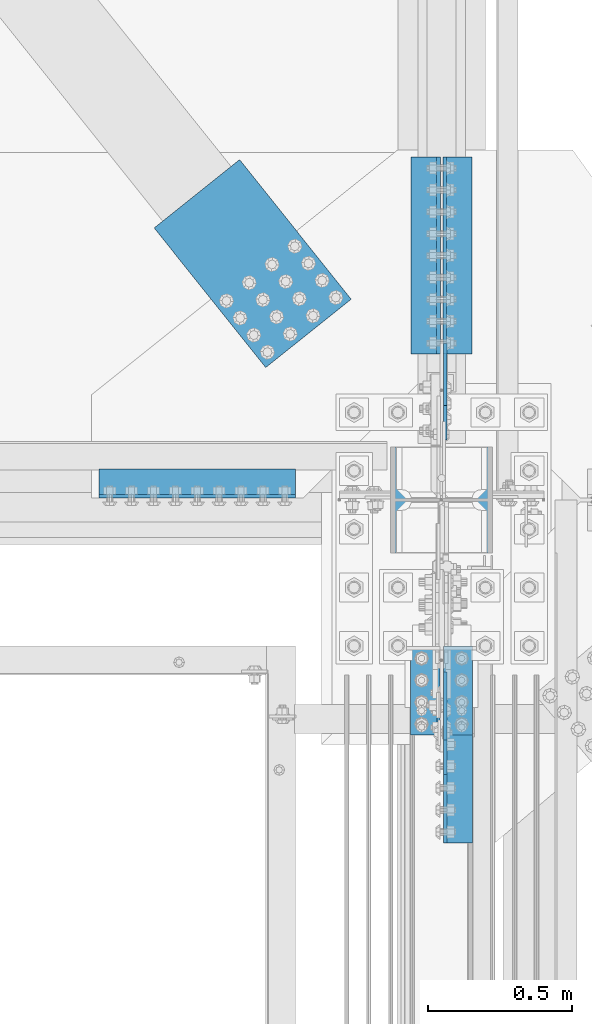
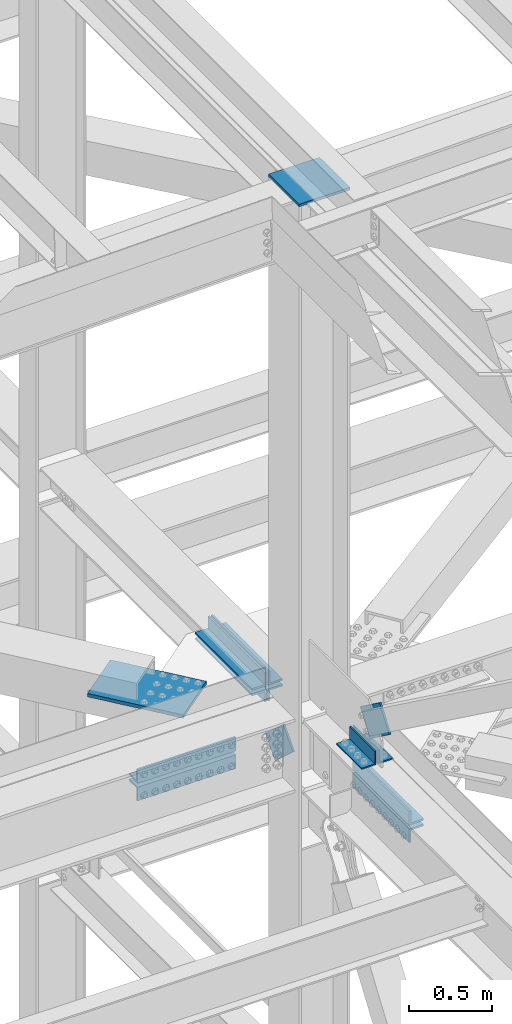
# One storey, part 2171 of 3843: 12 beams, 2 members, 9 elements without a shape of their own.
"""IFC2X3 building model written with IfcOpenShell, lengths in millimetres."""

import ifcopenshell
import ifcopenshell.guid

model = None  # the IFC model being written
_history = None  # IfcOwnerHistory: only IFC2X3 demands one
_inside = {}  # id of a spatial element -> (the spatial element, [elements in it])
_under = {}  # id of a project, library or spatial element -> (it, [spatial elements below it])
_declared = {}  # id of a project -> (the project, [libraries it declares])
_typed = {}  # id of a type object -> (the type object, [elements of that type])
_made_of = {}  # id of a material, layer set ... -> (it, [elements and type objects made of it])


def new_model(schema):
    """Start an empty IFC model of exactly this schema.

    Asked for "IFC4X3", IfcOpenShell would pick the latest addendum, in which some entities
    have other attributes; the version numbers below select the first issue.
    IFC2X3 requires an IfcOwnerHistory on every rooted entity: one is made here for all.
    """
    global model, _history
    if schema == "IFC4X3":
        model = ifcopenshell.file(schema_version=(4, 3, 0, 0))
    else:
        model = ifcopenshell.file(schema=schema)
    _inside.clear()
    _under.clear()
    _declared.clear()
    _typed.clear()
    _made_of.clear()
    _history = None
    if model.schema == "IFC2X3":
        org = make("IfcOrganization", Name="unknown")
        user = make(
            "IfcPersonAndOrganization",
            ThePerson=make("IfcPerson", FamilyName="unknown"),
            TheOrganization=org,
        )
        app = make(
            "IfcApplication",
            ApplicationDeveloper=org,
            Version="unknown",
            ApplicationFullName="unknown",
            ApplicationIdentifier="unknown",
        )
        _history = make(
            "IfcOwnerHistory",
            OwningUser=user,
            OwningApplication=app,
            ChangeAction="ADDED",
            CreationDate=0,
        )
    return model


def make(cls, **values):
    """One entity of the class cls with the attributes given. An attribute that is None is left unset."""
    return model.create_entity(
        cls, **{name: value for name, value in values.items() if value is not None}
    )


def rooted(cls, **values):
    """An entity with a GlobalId (a new one), such as an element, a storey or a relation."""
    return make(cls, GlobalId=ifcopenshell.guid.new(), OwnerHistory=_history, **values)


def si_unit(unit_type, name, prefix=None):
    """IfcSIUnit, for example si_unit("LENGTHUNIT", "METRE", prefix="MILLI")."""
    return make("IfcSIUnit", UnitType=unit_type, Prefix=prefix, Name=name)


def assignment(units):
    """IfcUnitAssignment: the units of a project."""
    return None if units is None else make("IfcUnitAssignment", Units=units)


def point(xyz):
    """IfcCartesianPoint."""
    return None if xyz is None else make("IfcCartesianPoint", Coordinates=xyz)


def direction(xyz):
    """IfcDirection."""
    return None if xyz is None else make("IfcDirection", DirectionRatios=xyz)


def frame(location, z_axis=None, x_axis=None):
    """IfcAxis2Placement3D, a coordinate frame: its origin and axes. An axis left out is left unset."""
    return make(
        "IfcAxis2Placement3D",
        Location=point(location),
        Axis=direction(z_axis),
        RefDirection=direction(x_axis),
    )


def origin_with_axes():
    """The frame at (0, 0, 0) with the z axis (0, 0, 1) and the x axis (1, 0, 0) written out."""
    return frame((0.0, 0.0, 0.0), z_axis=(0.0, 0.0, 1.0), x_axis=(1.0, 0.0, 0.0))


def place(relative_to, where):
    """IfcLocalPlacement: puts the frame where relative to a parent placement (None: the world)."""
    return make(
        "IfcLocalPlacement", PlacementRelTo=relative_to, RelativePlacement=where
    )


def context(
    kind, dimensions, precision=None, world=None, true_north=None, identifier=None
):
    """IfcGeometricRepresentationContext, for example the 3D "Model" context."""
    return make(
        "IfcGeometricRepresentationContext",
        ContextIdentifier=identifier,
        ContextType=kind,
        CoordinateSpaceDimension=dimensions,
        Precision=precision,
        WorldCoordinateSystem=world,
        TrueNorth=true_north,
    )


def subcontext(parent, identifier, kind, view, scale=None):
    """IfcGeometricRepresentationSubContext, for example "Body" below "Model"."""
    return make(
        "IfcGeometricRepresentationSubContext",
        ContextIdentifier=identifier,
        ContextType=kind,
        ParentContext=parent,
        TargetScale=scale,
        TargetView=view,
    )


def project(units=None, contexts=None):
    """IfcProject with its units and contexts."""
    return rooted(
        "IfcProject",
        Name="project",
        RepresentationContexts=contexts,
        UnitsInContext=assignment(units),
    )


def spatial(cls, under=None, at=None, **own):
    """A site, building, storey or space (cls), placed at a placement, below another one or the project."""
    s = rooted(cls, ObjectPlacement=at, **own)
    if under is not None:
        _under.setdefault(under.id(), (under, []))[1].append(s)
    return s


def faces_of(points, faces, orient=None, outer=None):
    """IfcFace entities. A face is a list of loops; a loop is a list of indices into points, from 0.

    orient and outer hold one flag for each loop. By default every Orientation is true, the
    first loop of a face is its IfcFaceOuterBound and the others are IfcFaceBound.
    """
    made = []
    for i, loops in enumerate(faces):
        bounds = []
        for j, loop in enumerate(loops):
            is_outer = j == 0 if outer is None else outer[i][j]
            bounds.append(
                make(
                    "IfcFaceOuterBound" if is_outer else "IfcFaceBound",
                    Bound=make("IfcPolyLoop", Polygon=[points[k] for k in loop]),
                    Orientation=True if orient is None else orient[i][j],
                )
            )
        made.append(make("IfcFace", Bounds=bounds))
    return made


def faceted_brep(points, faces, orient=None, outer=None, voids=None):
    """IfcFacetedBrep: a solid bounded by flat faces; with voids (closed shells), ...WithVoids."""
    shared = [point(p) for p in points]
    hull = make("IfcClosedShell", CfsFaces=faces_of(shared, faces, orient, outer))
    if voids is None:
        return make("IfcFacetedBrep", Outer=hull)
    return make(
        "IfcFacetedBrepWithVoids",
        Outer=hull,
        Voids=[
            make(cls, CfsFaces=faces_of(shared, fs, o, b)) for cls, fs, o, b in voids
        ],
    )


def shape(context_of_items, identifier, shape_type, items):
    """IfcShapeRepresentation: the items that make up one representation, for example the "Body"."""
    return make(
        "IfcShapeRepresentation",
        ContextOfItems=context_of_items,
        RepresentationIdentifier=identifier,
        RepresentationType=shape_type,
        Items=items,
    )


def material(Name=None, Category=None):
    """IfcMaterial."""
    return make("IfcMaterial", Name=Name, Category=Category)


def made_of(thing, what):
    """Note that an element or type object is made of a material, layer set ...; save() writes the relation."""
    if what is not None:
        _made_of.setdefault(what.id(), (what, []))[1].append(thing)
    return thing


def type_object(cls, material=None, **own):
    """A type object (cls), such as IfcWallType, which elements share."""
    return made_of(rooted(cls, **own), material)


def element(
    cls,
    number,
    at=None,
    inside=None,
    cuts=None,
    type_object=None,
    material=None,
    context=None,
    identifier="Body",
    shape_type=None,
    held_by="IfcProductDefinitionShape",
    body=None,
    shapes=None,
    **own,
):
    """One element of the class cls, such as IfcWall. Its Tag is "e" and its number.

    at: its placement. inside: the storey or other place that contains it. cuts: it is an
    opening in that element (IfcRelVoidsElement). A single representation is given by context,
    identifier, shape_type and body (its items); several are given by shapes. held_by: the class
    of the entity that holds the representations. save() writes the other relations.
    """
    e = rooted(cls, Tag="e%d" % number, ObjectPlacement=at, **own)
    if body is not None:
        shapes = [shape(context, identifier, shape_type, body)]
    if shapes is not None:
        e.Representation = make(held_by, Representations=shapes)
    if inside is not None:
        _inside.setdefault(inside.id(), (inside, []))[1].append(e)
    if cuts is not None:
        rooted(
            "IfcRelVoidsElement", RelatingBuildingElement=cuts, RelatedOpeningElement=e
        )
    if type_object is not None:
        _typed.setdefault(type_object.id(), (type_object, []))[1].append(e)
    return made_of(e, material)


def aggregate(whole, parts):
    """IfcRelAggregates: a whole, such as a stair, and the parts it consists of."""
    return rooted("IfcRelAggregates", RelatingObject=whole, RelatedObjects=parts)


def save(model, path):
    """Write the relations noted so far, then the file.

    IfcRelAggregates (storeys below a building ...), IfcRelContainedInSpatialStructure (elements
    in a storey), IfcRelDefinesByType, IfcRelAssociatesMaterial and IfcRelDeclares: one each for
    every whole, place, type object, material and project.
    """
    for whole, parts in _under.values():
        aggregate(whole, parts)
    for where, things in _inside.values():
        rooted(
            "IfcRelContainedInSpatialStructure",
            RelatedElements=things,
            RelatingStructure=where,
        )
    for kind, things in _typed.values():
        rooted("IfcRelDefinesByType", RelatedObjects=things, RelatingType=kind)
    for what, things in _made_of.values():
        rooted("IfcRelAssociatesMaterial", RelatedObjects=things, RelatingMaterial=what)
    for by, libraries in _declared.values():
        rooted("IfcRelDeclares", RelatingContext=by, RelatedDefinitions=libraries)
    model.write(path)


model = new_model("IFC2X3")

# Units and contexts
model_context = context("Model", 3, precision=1e-05, world=origin_with_axes())
body_context = subcontext(model_context, "Body", "Model", "MODEL_VIEW")
ifc_project = project(units=[si_unit("LENGTHUNIT", "METRE", prefix="MILLI"), si_unit("AREAUNIT", "SQUARE_METRE"), si_unit("VOLUMEUNIT", "CUBIC_METRE"), si_unit("MASSUNIT", "GRAM", prefix="KILO"), si_unit("TIMEUNIT", "SECOND"), si_unit("PLANEANGLEUNIT", "RADIAN"), si_unit("SOLIDANGLEUNIT", "STERADIAN"), si_unit("THERMODYNAMICTEMPERATUREUNIT", "DEGREE_CELSIUS"), si_unit("LUMINOUSINTENSITYUNIT", "LUMEN")], contexts=[model_context])

# Site, building, storey
site_placement = place(None, origin_with_axes())
site = spatial("IfcSite", under=ifc_project, at=site_placement, CompositionType="ELEMENT")
building_placement = place(site_placement, origin_with_axes())
building = spatial("IfcBuilding", under=site, at=building_placement, Name="Undefined", CompositionType="ELEMENT")
storey_placement = place(building_placement, origin_with_axes())
storey = spatial("IfcBuildingStorey", under=building, at=storey_placement, Name="Undefined", CompositionType="ELEMENT", Elevation=0.0)

# Assembly, beam
assembly_1_placement = place(storey_placement, origin_with_axes())
assembly_1 = element("IfcElementAssembly", 1, at=assembly_1_placement, inside=storey, Name="ANGLE", AssemblyPlace="NOTDEFINED", PredefinedType="RIGID_FRAME")
ifc_material = material(Name="STEEL/A572-50")
beam_type_1 = type_object("IfcBeamType", Name="L4X4X3/8", PredefinedType="NOTDEFINED")
beam_1_placement = place(assembly_1_placement, frame((77069.9499999709, 24797.5437500067, 42519.5999999896), z_axis=(0.0, 0.0, 1.0), x_axis=(0.0, 1.0, 0.0)))
beam_1 = element("IfcBeam", 2, at=beam_1_placement, type_object=beam_type_1, material=ifc_material, Name="ANGLE", ObjectType="L4X4X3/8", context=body_context, shape_type="Brep", body=[
    faceted_brep([(0.0, 50.8000000000029, -50.8000000000029), (0.0, 50.8000000000029, 50.8000000000029), (304.800000000003, 50.8000000000029, 50.8000000000029), (304.800000000003, 50.8000000000029, -50.8000000000029), (0.0, 41.2750000000015, 50.8000000000029), (304.800000000003, 41.2749999999942, 50.8000000000029), (0.0, 41.2749999999942, -41.2750000000015), (304.800000000003, 41.2749999999942, -41.2750000000015), (0.0, -50.8000000000029, -41.2750000000015), (304.800000000003, -50.8000000000029, -41.2750000000015), (0.0, -50.8000000000029, -50.8000000000029), (304.800000000003, -50.8000000000029, -50.8000000000029)], [[[0, 1, 2, 3]], [[1, 4, 5, 2]], [[4, 6, 7, 5]], [[6, 8, 9, 7]], [[8, 10, 11, 9]], [[10, 0, 3, 11]], [[5, 7, 9, 11, 3, 2]], [[10, 8, 6, 4, 1, 0]]]),
])
aggregate(assembly_1, [beam_1])

assembly_2_placement = place(storey_placement, origin_with_axes())
assembly_2 = element("IfcElementAssembly", 3, at=assembly_2_placement, inside=storey, Name="ANGLE", AssemblyPlace="NOTDEFINED", PredefinedType="RIGID_FRAME")
beam_2_placement = place(assembly_2_placement, frame((76955.6499999709, 25102.3437500067, 42519.5999999896), z_axis=(0.0, 0.0, 1.0), x_axis=(0.0, -1.0, 0.0)))
beam_2 = element("IfcBeam", 4, at=beam_2_placement, type_object=beam_type_1, material=ifc_material, Name="ANGLE", ObjectType="L4X4X3/8", context=body_context, shape_type="Brep", body=[
    faceted_brep([(0.0, 50.8000000000029, -50.8000000000029), (0.0, 50.8000000000029, 50.8000000000029), (304.800000000003, 50.8000000000029, 50.8000000000029), (304.800000000003, 50.8000000000029, -50.8000000000029), (0.0, 41.2750000000015, 50.8000000000029), (304.800000000003, 41.2749999999942, 50.8000000000029), (0.0, 41.2749999999942, -41.2750000000015), (304.800000000003, 41.2749999999942, -41.2750000000015), (0.0, -50.8000000000029, -41.2750000000015), (304.800000000003, -50.8000000000029, -41.2750000000015), (0.0, -50.8000000000029, -50.8000000000029), (304.800000000003, -50.8000000000029, -50.8000000000029)], [[[0, 1, 2, 3]], [[1, 4, 5, 2]], [[4, 6, 7, 5]], [[6, 8, 9, 7]], [[8, 10, 11, 9]], [[10, 0, 3, 11]], [[5, 7, 9, 11, 3, 2]], [[10, 8, 6, 4, 1, 0]]]),
])
aggregate(assembly_2, [beam_2])

# Assembly, beams
assembly_3_placement = place(storey_placement, origin_with_axes())
assembly_3 = element("IfcElementAssembly", 5, at=assembly_3_placement, inside=storey, Name="PLATE", AssemblyPlace="NOTDEFINED", PredefinedType="RIGID_FRAME")
beam_type_2 = type_object("IfcBeamType", Name="L4X4X1/2", PredefinedType="NOTDEFINED")
beam_3_placement = place(assembly_3_placement, frame((77069.9499999965, 25107.9, 42297.35), z_axis=(1.0, 0.0, 0.0), x_axis=(0.0, -1.0, 0.0)))
beam_3 = element("IfcBeam", 6, at=beam_3_placement, type_object=beam_type_2, material=ifc_material, Name="ANGLE", ObjectType="L4X4X1/2", context=body_context, shape_type="Brep", body=[
    faceted_brep([(0.0, 50.8000000000029, -50.8000000000029), (0.0, 50.8000000000029, 50.8000000000029), (685.800000000003, 50.8000000000029, 50.8000000000029), (685.800000000003, 50.8000000000029, -50.8000000000029), (0.0, 38.0999999999985, 50.8000000000029), (685.800000000003, 38.0999999999985, 50.8000000000029), (0.0, 38.0999999999985, -38.0999999999985), (685.800000000003, 38.0999999999985, -38.1000000000058), (0.0, -50.8000000000029, -38.1000000000058), (685.800000000003, -50.8000000000029, -38.1000000000058), (0.0, -50.8000000000029, -50.8000000000029), (685.800000000003, -50.8000000000029, -50.8000000000029)], [[[0, 1, 2, 3]], [[1, 4, 5, 2]], [[4, 6, 7, 5]], [[6, 8, 9, 7]], [[8, 10, 11, 9]], [[10, 0, 3, 11]], [[5, 7, 9, 11, 3, 2]], [[10, 8, 6, 4, 1, 0]]]),
])
beam_4_placement = place(assembly_3_placement, frame((77069.9499999965, 24422.1, 42167.175), z_axis=(1.0, 0.0, 0.0), x_axis=(0.0, 1.0, 0.0)))
beam_4 = element("IfcBeam", 7, at=beam_4_placement, type_object=beam_type_2, material=ifc_material, Name="ANGLE", ObjectType="L4X4X1/2", context=body_context, shape_type="Brep", body=[
    faceted_brep([(0.0, 50.8000000000029, -50.8000000000029), (0.0, 50.8000000000029, 50.8000000000029), (685.800000000003, 50.8000000000029, 50.8000000000029), (685.800000000003, 50.8000000000029, -50.8000000000029), (0.0, 38.0999999999985, 50.8000000000029), (685.800000000003, 38.0999999999985, 50.8000000000029), (0.0, 38.0999999999985, -38.0999999999985), (685.800000000003, 38.0999999999985, -38.1000000000058), (0.0, -50.8000000000029, -38.1000000000058), (685.800000000003, -50.8000000000029, -38.1000000000058), (0.0, -50.8000000000029, -50.8000000000029), (685.800000000003, -50.8000000000029, -50.8000000000029)], [[[0, 1, 2, 3]], [[1, 4, 5, 2]], [[4, 6, 7, 5]], [[6, 8, 9, 7]], [[8, 10, 11, 9]], [[10, 0, 3, 11]], [[5, 7, 9, 11, 3, 2]], [[10, 8, 6, 4, 1, 0]]]),
])
aggregate(assembly_3, [beam_3, beam_4])

# Assembly, beam
assembly_4_placement = place(storey_placement, origin_with_axes())
assembly_4 = element("IfcElementAssembly", 8, at=assembly_4_placement, inside=storey, Name="PLATE", AssemblyPlace="NOTDEFINED", PredefinedType="RIGID_FRAME")
beam_5_placement = place(assembly_4_placement, frame((77068.3625000016, 26809.7, 42297.3500007629), z_axis=(1.0, 0.0, 0.0), x_axis=(0.0, -1.0, 0.0)))
beam_5 = element("IfcBeam", 9, at=beam_5_placement, type_object=beam_type_2, material=ifc_material, Name="ANGLE", ObjectType="L4X4X1/2", context=body_context, shape_type="Brep", body=[
    faceted_brep([(0.0, 50.8000000000029, -50.8000000000029), (0.0, 50.8000000000029, 50.8000000000029), (685.800000000003, 50.8000000000029, 50.8000000000029), (685.800000000003, 50.8000000000029, -50.8000000000029), (0.0, 38.0999999999985, 50.8000000000029), (685.800000000003, 38.0999999999985, 50.8000000000029), (0.0, 38.0999999999985, -38.0999999999985), (685.800000000003, 38.0999999999985, -38.1000000000058), (0.0, -50.8000000000029, -38.1000000000058), (685.800000000003, -50.8000000000029, -38.1000000000058), (0.0, -50.8000000000029, -50.8000000000029), (685.800000000003, -50.8000000000029, -50.8000000000029)], [[[0, 1, 2, 3]], [[1, 4, 5, 2]], [[4, 6, 7, 5]], [[6, 8, 9, 7]], [[8, 10, 11, 9]], [[10, 0, 3, 11]], [[5, 7, 9, 11, 3, 2]], [[10, 8, 6, 4, 1, 0]]]),
])

# Assembly, beams
assembly_5_placement = place(storey_placement, origin_with_axes())
assembly_5 = element("IfcElementAssembly", 10, at=assembly_5_placement, inside=storey, Name="PLATE", AssemblyPlace="NOTDEFINED", PredefinedType="RIGID_FRAME")
beam_6_placement = place(assembly_5_placement, frame((75819.0000000007, 25673.0499999693, 42297.3500007629), z_axis=(0.0, 1.0, 0.0), x_axis=(1.0, 0.0, 0.0)))
beam_6 = element("IfcBeam", 11, at=beam_6_placement, type_object=beam_type_2, material=ifc_material, Name="ANGLE", ObjectType="L4X4X1/2", context=body_context, shape_type="Brep", body=[
    faceted_brep([(0.0, 50.8000000000029, -50.8000000000029), (0.0, 50.8000000000029, 50.8000000000029), (685.800000000003, 50.8000000000029, 50.8000000000029), (685.800000000003, 50.8000000000029, -50.8000000000029), (0.0, 38.0999999999985, 50.8000000000029), (685.800000000003, 38.0999999999985, 50.8000000000029), (0.0, 38.0999999999985, -38.0999999999985), (685.800000000003, 38.0999999999985, -38.1000000000058), (0.0, -50.8000000000029, -38.1000000000058), (685.800000000003, -50.8000000000029, -38.1000000000058), (0.0, -50.8000000000029, -50.8000000000029), (685.800000000003, -50.8000000000029, -50.8000000000029)], [[[0, 1, 2, 3]], [[1, 4, 5, 2]], [[4, 6, 7, 5]], [[6, 8, 9, 7]], [[8, 10, 11, 9]], [[10, 0, 3, 11]], [[5, 7, 9, 11, 3, 2]], [[10, 8, 6, 4, 1, 0]]]),
])
beam_7_placement = place(assembly_5_placement, frame((76504.8000000008, 25673.0499999593, 42167.175), z_axis=(0.0, 1.0, 0.0), x_axis=(-1.0, 0.0, 0.0)))
beam_7 = element("IfcBeam", 12, at=beam_7_placement, type_object=beam_type_2, material=ifc_material, Name="ANGLE", ObjectType="L4X4X1/2", context=body_context, shape_type="Brep", body=[
    faceted_brep([(0.0, 50.8000000000029, -50.8000000000029), (0.0, 50.8000000000029, 50.8000000000029), (685.800000000003, 50.8000000000029, 50.8000000000029), (685.800000000003, 50.8000000000029, -50.8000000000029), (0.0, 38.0999999999985, 50.8000000000029), (685.800000000003, 38.0999999999985, 50.8000000000029), (0.0, 38.0999999999985, -38.0999999999985), (685.800000000003, 38.0999999999985, -38.1000000000058), (0.0, -50.8000000000029, -38.1000000000058), (685.800000000003, -50.8000000000029, -38.1000000000058), (0.0, -50.8000000000029, -50.8000000000029), (685.800000000003, -50.8000000000029, -50.8000000000029)], [[[0, 1, 2, 3]], [[1, 4, 5, 2]], [[4, 6, 7, 5]], [[6, 8, 9, 7]], [[8, 10, 11, 9]], [[10, 0, 3, 11]], [[5, 7, 9, 11, 3, 2]], [[10, 8, 6, 4, 1, 0]]]),
])
beam_8_placement = place(assembly_5_placement, frame((76957.2374999851, 26123.9000000008, 42297.3500007629), z_axis=(-1.0, 0.0, 0.0), x_axis=(0.0, 1.0, 0.0)))
beam_8 = element("IfcBeam", 13, at=beam_8_placement, type_object=beam_type_2, material=ifc_material, Name="ANGLE", ObjectType="L4X4X1/2", context=body_context, shape_type="Brep", body=[
    faceted_brep([(0.0, 50.8000000000029, -50.8000000000029), (0.0, 50.8000000000029, 50.8000000000029), (685.800000000003, 50.8000000000029, 50.8000000000029), (685.800000000003, 50.8000000000029, -50.8000000000029), (0.0, 38.0999999999985, 50.8000000000029), (685.800000000003, 38.0999999999985, 50.8000000000029), (0.0, 38.0999999999985, -38.0999999999985), (685.800000000003, 38.0999999999985, -38.1000000000058), (0.0, -50.8000000000029, -38.1000000000058), (685.800000000003, -50.8000000000029, -38.1000000000058), (0.0, -50.8000000000029, -50.8000000000029), (685.800000000003, -50.8000000000029, -50.8000000000029)], [[[0, 1, 2, 3]], [[1, 4, 5, 2]], [[4, 6, 7, 5]], [[6, 8, 9, 7]], [[8, 10, 11, 9]], [[10, 0, 3, 11]], [[5, 7, 9, 11, 3, 2]], [[10, 8, 6, 4, 1, 0]]]),
])

# Assembly, member
assembly_6_placement = place(storey_placement, origin_with_axes())
assembly_6 = element("IfcElementAssembly", 14, at=assembly_6_placement, inside=storey, AssemblyPlace="NOTDEFINED", PredefinedType="RIGID_FRAME")
member_type_1 = type_object("IfcMemberType", PredefinedType="NOTDEFINED")
member_1_placement = place(assembly_6_placement, frame((77025.4999999709, 24956.4514121109, 42677.9098943914), z_axis=(0.0, 0.588951675939947, 0.808168251917587), x_axis=(0.0, -0.808168251917582, 0.588951675939953)))
member_1 = element("IfcMember", 15, at=member_1_placement, type_object=member_type_1, material=ifc_material, Name="PLATE", context=body_context, shape_type="Brep", body=[
    faceted_brep([(1.74622982740402e-10, 6.35000000000582, -101.600000000195), (-1.67347025126219e-10, 6.35000000000582, 101.600000000151), (292.1000000028, 6.35000000000582, 101.600000000661), (292.100000003156, 6.35000000000582, -101.599999999686), (-1.67347025126219e-10, -6.35000000000582, 101.600000000151), (292.1000000028, -6.35000000000582, 101.600000000661), (1.74622982740402e-10, -6.35000000000582, -101.600000000195), (292.100000003156, -6.35000000000582, -101.599999999686)], [[[0, 1, 2, 3]], [[1, 4, 5, 2]], [[4, 6, 7, 5]], [[6, 0, 3, 7]], [[5, 7, 3, 2]], [[6, 4, 1, 0]]]),
])
aggregate(assembly_6, [member_1])

# Beam
beam_type_3 = type_object("IfcBeamType", Name="L4X3-1/2X1/2", PredefinedType="NOTDEFINED")
beam_9_placement = place(assembly_5_placement, frame((76957.2375000113, 26809.7, 42173.5245007629), z_axis=(-1.0, 0.0, 0.0), x_axis=(0.0, -1.0, 0.0)))
beam_9 = element("IfcBeam", 16, at=beam_9_placement, type_object=beam_type_3, material=ifc_material, Name="ANGLE", ObjectType="L4X3-1/2X1/2", context=body_context, shape_type="Brep", body=[
    faceted_brep([(0.0, 44.4499999999971, -50.8000000000029), (0.0, 44.4499999999971, 50.8000000000029), (685.800000000003, 44.4499999999971, 50.8000000000029), (685.800000000003, 44.4499999999971, -50.8000000000029), (0.0, 31.75, 50.8000000000029), (685.800000000003, 31.75, 50.8000000000029), (0.0, 31.7500000838336, -38.0999999999985), (685.800000000003, 31.75, -38.0999999999985), (4.36557456851006e-11, -44.4500000000226, -38.0999999999985), (685.800000000003, -44.4499999999971, -38.0999999999985), (0.0, -44.4499999999971, -50.8000000000029), (685.800000000003, -44.4499999999971, -50.8000000000029)], [[[0, 1, 2, 3]], [[1, 4, 5, 2]], [[4, 6, 7, 5]], [[6, 8, 9, 7]], [[8, 10, 11, 9]], [[10, 0, 3, 11]], [[5, 7, 9, 11, 3, 2]], [[10, 8, 6, 4, 1, 0]]]),
])

aggregate(assembly_5, [beam_9, beam_6, beam_7, beam_8])

beam_10_placement = place(assembly_4_placement, frame((77068.3625000016, 26123.9, 42173.5245007629), z_axis=(1.0, 0.0, 0.0), x_axis=(0.0, 1.0, 0.0)))
beam_10 = element("IfcBeam", 17, at=beam_10_placement, type_object=beam_type_3, material=ifc_material, Name="ANGLE", ObjectType="L4X3-1/2X1/2", context=body_context, shape_type="Brep", body=[
    faceted_brep([(0.0, 44.4499999999971, -50.8000000000029), (0.0, 44.4499999999971, 50.8000000000029), (685.800000000003, 44.4499999999971, 50.8000000000029), (685.800000000003, 44.4499999999971, -50.8000000000029), (0.0, 31.75, 50.8000000000029), (685.800000000003, 31.75, 50.8000000000029), (0.0, 31.7500000838336, -38.0999999999985), (685.800000000003, 31.75, -38.0999999999985), (4.36557456851006e-11, -44.4500000000226, -38.0999999999985), (685.800000000003, -44.4499999999971, -38.0999999999985), (0.0, -44.4499999999971, -50.8000000000029), (685.800000000003, -44.4499999999971, -50.8000000000029)], [[[0, 1, 2, 3]], [[1, 4, 5, 2]], [[4, 6, 7, 5]], [[6, 8, 9, 7]], [[8, 10, 11, 9]], [[10, 0, 3, 11]], [[5, 7, 9, 11, 3, 2]], [[10, 8, 6, 4, 1, 0]]]),
])

aggregate(assembly_4, [beam_10, beam_5])

# Assembly, member
assembly_7_placement = place(storey_placement, origin_with_axes())
assembly_7 = element("IfcElementAssembly", 18, at=assembly_7_placement, inside=storey, AssemblyPlace="NOTDEFINED", PredefinedType="RIGID_FRAME")
member_type_2 = type_object("IfcMemberType", PredefinedType="NOTDEFINED")
member_2_placement = place(assembly_7_placement, frame((77025.5, 25884.9974157268, 42001.4397514531), z_axis=(0.0, -0.673388817040856, -0.739288510044838), x_axis=(0.0, 0.739288510044847, -0.673388817040846)))
member_2 = element("IfcMember", 19, at=member_2_placement, type_object=member_type_2, material=ifc_material, Name="PLATE", context=body_context, shape_type="Brep", body=[
    faceted_brep([(1.45519152283669e-11, 6.35000000000582, -88.8999999998996), (0.0, 6.34999999999854, 88.9000015258789), (292.099999998526, 6.35000000000582, 88.900000000016), (292.099999999057, 6.35000000000582, -88.8999999997031), (0.0, -6.34999999999854, 88.9000015258789), (292.099999998526, -6.35000000000582, 88.900000000016), (1.45519152283669e-11, -6.35000000000582, -88.8999999998996), (292.099999999057, -6.35000000000582, -88.8999999997031)], [[[0, 1, 2, 3]], [[1, 4, 5, 2]], [[4, 6, 7, 5]], [[6, 0, 3, 7]], [[5, 7, 3, 2]], [[6, 4, 1, 0]]]),
])
aggregate(assembly_7, [member_2])

# Assembly, beam
assembly_8_placement = place(storey_placement, origin_with_axes())
assembly_8 = element("IfcElementAssembly", 20, at=assembly_8_placement, inside=storey, AssemblyPlace="NOTDEFINED", PredefinedType="RIGID_FRAME")
beam_type_4 = type_object("IfcBeamType", PredefinedType="NOTDEFINED")
beam_11_placement = place(assembly_8_placement, frame((76549.0694419901, 26196.0108031779, 42259.25), z_axis=(0.781103955949756, 0.624401000959833, 0.0), x_axis=(-0.624401003155538, 0.781103954194548, 0.0)))
beam_11 = element("IfcBeam", 21, at=beam_11_placement, type_object=beam_type_4, material=ifc_material, Name="PLATE", context=body_context, shape_type="Brep", body=[
    faceted_brep([(5.85714587941766e-10, 12.6999999999971, -190.500000000349), (-6.14818418398499e-10, 12.6999999999971, 190.500000000364), (622.299987794569, 12.6999999999971, 190.499999998057), (622.299987793129, 12.6999999999971, -190.500000002765), (-6.14818418398499e-10, -12.6999999999971, 190.500000000364), (622.299987794569, -12.6999999999971, 190.499999998057), (5.85714587941766e-10, -12.6999999999971, -190.500000000349), (622.299987793129, -12.6999999999971, -190.500000002765)], [[[0, 1, 2, 3]], [[1, 4, 5, 2]], [[4, 6, 7, 5]], [[6, 0, 3, 7]], [[5, 7, 3, 2]], [[6, 4, 1, 0]]]),
])
aggregate(assembly_8, [beam_11])

assembly_9_placement = place(storey_placement, origin_with_axes())
assembly_9 = element("IfcElementAssembly", 22, at=assembly_9_placement, inside=storey, Name="COLUMN", AssemblyPlace="NOTDEFINED", PredefinedType="RIGID_FRAME")
beam_type_5 = type_object("IfcBeamType", PredefinedType="NOTDEFINED")
beam_12_placement = place(assembly_9_placement, frame((77190.6, 25615.9, 46264.3645639882), z_axis=(0.0, 1.0, 0.0), x_axis=(-1.0, 0.0, 0.0)))
beam_12 = element("IfcBeam", 23, at=beam_12_placement, type_object=beam_type_5, material=ifc_material, Name="PLATE", context=body_context, shape_type="Brep", body=[
    faceted_brep([(0.0, 9.52500000000146, -184.150000000001), (0.0, 9.52500000000146, 184.150000000001), (355.600000000006, 9.52500000000146, 184.150000000001), (355.600000000006, 9.52500000000146, -184.150000000001), (0.0, -9.52500000000146, 184.150000000001), (355.600000000006, -9.52500000000146, 184.150000000001), (0.0, -9.52500000000146, -184.150000000001), (355.600000000006, -9.52500000000146, -184.150000000001)], [[[0, 1, 2, 3]], [[1, 4, 5, 2]], [[4, 6, 7, 5]], [[6, 0, 3, 7]], [[5, 7, 3, 2]], [[6, 4, 1, 0]]]),
])
aggregate(assembly_9, [beam_12])

save(model, "model.ifc")
